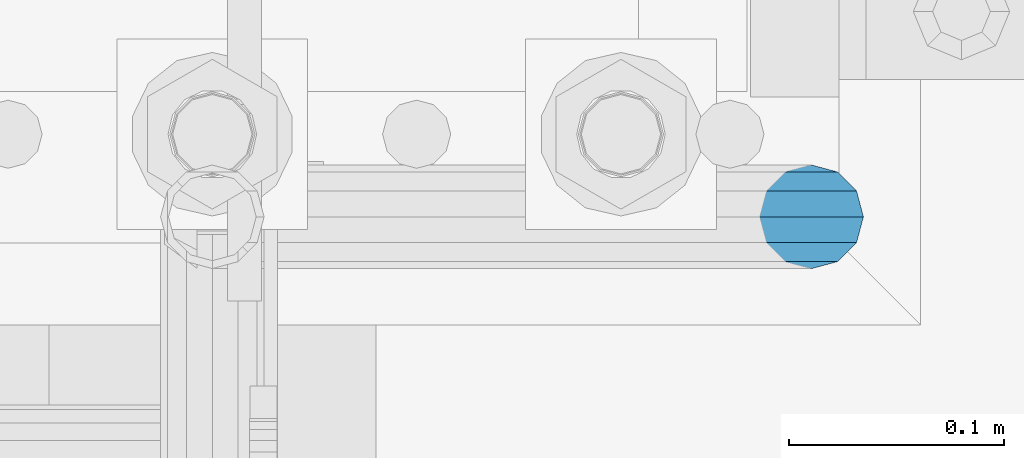
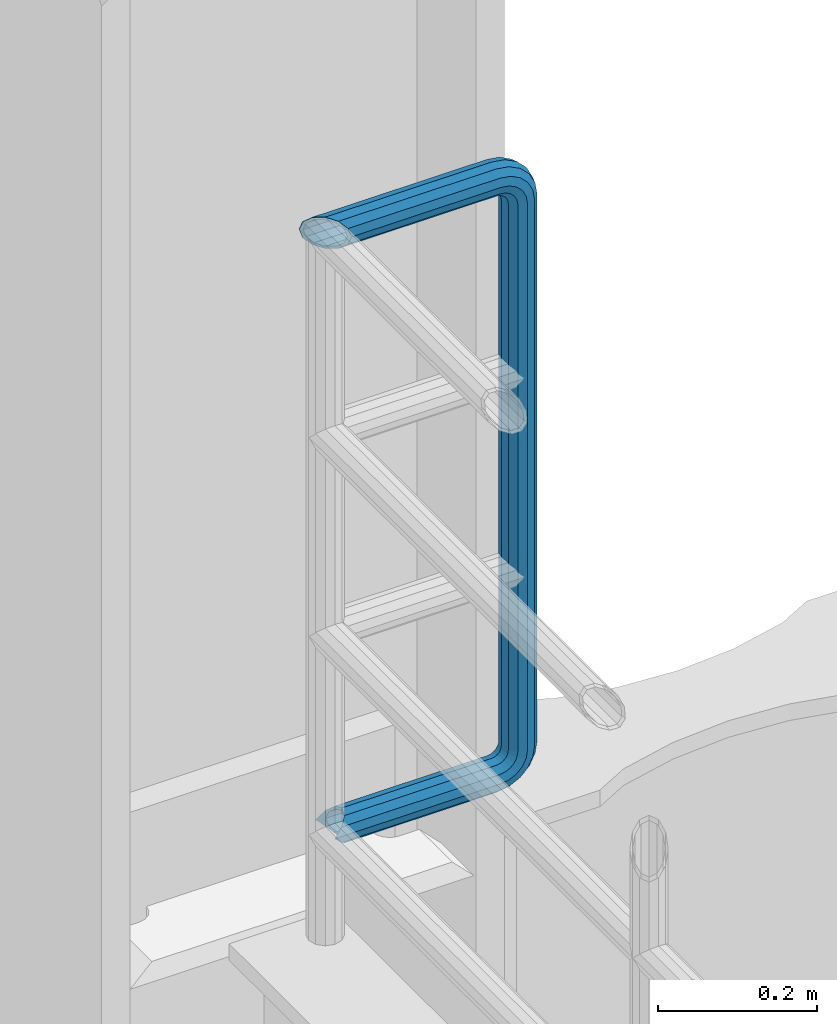
# One storey, part 1054 of 1876: 1 beam, 1 element without a shape of its own.
"""IFC2X3 building model written with IfcOpenShell, lengths in millimetres."""

from ifc_helpers import new_model, si_unit, frame, origin_with_axes, place, context, subcontext, project, spatial, faceted_brep, material, type_object, element, aggregate, save


model = new_model("IFC2X3")

# Units and contexts
model_context = context("Model", 3, precision=1e-05, world=origin_with_axes())
body_context = subcontext(model_context, "Body", "Model", "MODEL_VIEW")
ifc_project = project(units=[si_unit("LENGTHUNIT", "METRE", prefix="MILLI"), si_unit("AREAUNIT", "SQUARE_METRE"), si_unit("VOLUMEUNIT", "CUBIC_METRE"), si_unit("MASSUNIT", "GRAM", prefix="KILO"), si_unit("TIMEUNIT", "SECOND"), si_unit("PLANEANGLEUNIT", "RADIAN"), si_unit("SOLIDANGLEUNIT", "STERADIAN"), si_unit("THERMODYNAMICTEMPERATUREUNIT", "DEGREE_CELSIUS"), si_unit("LUMINOUSINTENSITYUNIT", "LUMEN")], contexts=[model_context])

# Site, building, storey
site_placement = place(None, origin_with_axes())
site = spatial("IfcSite", under=ifc_project, at=site_placement, CompositionType="ELEMENT")
building_placement = place(site_placement, origin_with_axes())
building = spatial("IfcBuilding", under=site, at=building_placement, Name="Undefined", CompositionType="ELEMENT")
storey_placement = place(building_placement, origin_with_axes())
storey = spatial("IfcBuildingStorey", under=building, at=storey_placement, Name="Undefined", CompositionType="ELEMENT", Elevation=0.0)

# Assembly, beam
assembly_placement = place(storey_placement, origin_with_axes())
assembly = element("IfcElementAssembly", 1, at=assembly_placement, inside=storey, Name="RAIL", AssemblyPlace="NOTDEFINED", PredefinedType="RIGID_FRAME")
ifc_material = material()
beam_type = type_object("IfcBeamType", Name="PIPE1-1/2SCH40", PredefinedType="NOTDEFINED")
beam_placement = place(assembly_placement, frame((-3.18323145620525e-12, 13499.7063, 19059.525), z_axis=(0.0, 0.0, 1.0), x_axis=(1.0, 0.0, 0.0)))
beam = element("IfcBeam", 2, at=beam_placement, type_object=beam_type, material=ifc_material, Name="RAIL", ObjectType="PIPE1-1/2SCH40", context=body_context, shape_type="Brep", body=[
    faceted_brep([(1.20714750983051e-12, 24.1299999999974, -914.399963378906), (12.0650000000014, 20.8971929933159, -926.464963378905), (12.0650000000014, 20.8971929933177, -902.334963378908), (12.0650000000014, -20.8971929933195, -902.334963378908), (12.0650000000014, -20.8971929933195, -926.464963378905), (1.52133659548828e-12, -24.130000000001, -914.399963378906), (20.8971929933199, -12.0650000000023, -893.502770385589), (20.8971929933199, -12.0650000000005, -898.533841947723), (15.2545715621378, -17.7076214311819, -904.176463378906), (12.5151929933181, -20.4470000000019, -914.399963378906), (15.2545715621376, -17.7076214311819, -924.623463378906), (20.8971929933199, -12.0650000000005, -930.26608481009), (20.8971929933199, -12.0650000000023, -935.297156372224), (24.1300000000014, -1.81898940354586e-12, -934.846963378906), (24.1300000000014, -1.81898940354586e-12, -938.529963378907), (21.3906214311813, -10.2235000000019, -932.107584810088), (21.3906214311823, 10.2234999999982, -932.107584810088), (20.8971929933199, 12.0650000000005, -930.266084810086), (20.8971929933199, 12.0649999999987, -935.297156372224), (15.2545715621413, 17.7076214311783, -924.623463378906), (12.5151929933216, 20.4469999999983, -914.399963378906), (15.2545715621411, 17.7076214311783, -904.176463378906), (20.8971929933199, 12.0650000000005, -898.533841947727), (20.8971929933199, 12.0649999999987, -893.502770385589), (21.3906214311822, 10.2234999999982, -896.692341947724), (24.1300000000014, 0.0, -893.952963378906), (24.1300000000014, 0.0, -890.269963378905), (21.3906214311814, -10.2235000000019, -896.692341947724), (241.299995422363, -20.8971929933177, 12.0649999999987), (241.299995422363, -24.1299999999992, 0.0), (253.073542436527, -24.1299999999992, -1.86474665447167), (256.801832473661, -20.8971929933177, 9.60975021462946), (241.299995422363, -12.0650000000005, 20.8971929933177), (259.531130206197, -12.0650000000005, 18.0096649141014), (241.299995422363, 0.0, 24.130000000001), (260.530122510796, 0.0, 21.084247083727), (241.299995422363, 12.0650000000005, 20.8971929933177), (259.531130206197, 12.0650000000005, 18.0096649141014), (241.299995422363, 20.8971929933177, 12.0649999999987), (256.801832473661, 20.8971929933177, 9.60975021462946), (241.299995422363, 24.1299999999992, 0.0), (253.073542436527, 24.1299999999992, -1.86474665447167), (241.299995422363, 20.8971929933177, -12.0649999999987), (249.345252399393, 20.8971929933177, -13.3392435235728), (241.299995422363, 12.0650000000005, -20.8971929933177), (246.615954666858, 12.0650000000005, -21.7391582230448), (241.299995422363, 0.0, -24.130000000001), (245.616962362259, 0.0, -24.8137403926739), (241.299995422363, -12.0650000000005, -20.8971929933177), (246.615954666858, -12.0650000000005, -21.7391582230448), (241.299995422363, -20.8971929933177, -12.0649999999987), (249.345252399393, -20.8971929933177, -13.3392435235728), (267.334993896485, 20.8971929933177, -38.0999984741211), (279.399993896485, 24.1299999999992, -38.0999984741211), (279.399993896484, 24.1299999999992, -876.299964904785), (267.334993896484, 20.8971929933177, -876.299964904785), (291.464993896486, 20.8971929933177, -38.0999984741211), (291.464993896484, 20.8971929933177, -876.299964904785), (300.297186889804, 12.0650000000005, -38.0999984741211), (300.297186889803, 12.0650000000005, -876.299964904785), (303.529993896486, 0.0, -38.0999984741211), (303.529993896484, 0.0, -876.299964904785), (300.297186889804, -12.0650000000005, -38.0999984741211), (300.297186889803, -12.0650000000005, -876.299964904785), (291.464993896486, -20.8971929933177, -38.0999984741211), (291.464993896484, -20.8971929933177, -876.299964904785), (279.399993896484, -24.1299999999992, -38.0999984741211), (279.399993896484, -24.1299999999992, -876.299964904785), (267.334993896485, -20.8971929933177, -38.0999984741211), (267.334993896484, -20.8971929933177, -876.299964904785), (258.502800903167, -12.0650000000005, -38.0999984741211), (258.502800903166, -12.0650000000005, -876.299964904785), (255.269993896485, 0.0, -38.0999984741211), (255.269993896484, 0.0, -876.299964904785), (258.502800903167, 12.0650000000005, -38.0999984741211), (258.502800903166, 12.0650000000005, -876.299964904785), (257.660835673438, 12.0650000000005, -881.615924149282), (254.586253503809, 0.0, -880.616931844681), (257.660835673438, -12.0650000000005, -881.615924149282), (266.06075037291, -20.8971929933177, -884.345221881817), (277.535247242011, -24.130000000001, -888.073511918952), (289.009744111112, -20.8971929933195, -891.801801956084), (297.409658810584, -12.0650000000005, -894.531099688622), (300.484240980214, 0.0, -895.53009199322), (297.409658810584, 12.0650000000005, -894.531099688622), (289.009744111112, 20.8971929933177, -891.801801956084), (277.535247242011, 24.1299999999992, -888.073511918952), (266.06075037291, 20.8971929933177, -884.345221881817), (241.299995422364, -1.81898940354586e-12, -938.529963378911), (241.299995422364, -12.0650000000005, -935.297156372228), (241.299995422364, -20.8971929933195, -926.464963378909), (241.299995422363, -24.130000000001, -914.399963378906), (241.299995422363, -20.8971929933195, -902.334963378908), (241.299995422363, -12.0650000000005, -893.502770385589), (241.299995422363, 0.0, -890.269963378909), (241.299995422364, 20.8971929933177, -926.464963378909), (241.299995422364, 12.0649999999987, -935.297156372228), (241.299995422364, 24.1299999999992, -914.39996337891), (241.299995422363, 20.8971929933177, -902.334963378908), (241.299995422363, 12.0649999999987, -893.502770385589), (260.530122510801, 0.0, -935.484210462637), (259.531130206202, 12.0649999999987, -932.409628293008), (259.531130206201, -12.0650000000005, -932.409628293008), (256.801832473666, -20.8971929933195, -924.009713593536), (253.07354243653, -24.130000000001, -912.535216724435), (249.345252399395, -20.8971929933195, -901.060719855333), (246.615954666859, -12.0650000000005, -892.660805155861), (245.61696236226, 0.0, -889.586222986232), (246.615954666859, 12.0649999999987, -892.660805155861), (249.345252399395, 20.8971929933177, -901.060719855333), (253.07354243653, 24.1299999999992, -912.535216724435), (256.801832473666, 20.8971929933177, -924.009713593536), (275.977674493594, 12.0649999999987, -924.029695422345), (270.786241706733, 20.8971929933177, -916.884301193139), (277.877870775644, 0.0, -926.645091230272), (275.977674493608, -12.0650000000005, -924.029695422334), (270.786241706733, -20.8971929933195, -916.884301193139), (263.694612637823, -24.130000000001, -907.123511156005), (256.602983568912, -20.8971929933195, -897.362721118872), (251.411550782037, -12.0650000000005, -890.21732688968), (249.511354500001, 0.0, -887.601931081743), (251.411550782037, 12.0650000000005, -890.21732688968), (256.602983568912, 20.8971929933177, -897.362721118872), (263.694612637823, 24.1299999999992, -907.123511156005), (281.884331710718, 20.8971929933177, -905.786211189152), (272.123541673585, 24.1299999999992, -898.694582120243), (289.029725939912, 12.0650000000005, -910.977643976028), (291.645121747852, 0.0, -912.877840258065), (289.029725939912, -12.0650000000005, -910.977643976028), (281.884331710718, -20.8971929933195, -905.786211189152), (272.123541673585, -24.130000000001, -898.694582120243), (262.362751636451, -20.8971929933195, -891.602953051333), (255.217357407258, -12.0650000000005, -886.411520264461), (252.601961599318, 0.0, -884.511323982424), (255.217357407258, 12.0650000000005, -886.411520264461), (262.362751636451, 20.8971929933177, -891.602953051333), (266.060750372911, 20.8971929933177, -30.0547414970897), (257.660835673439, 12.0650000000005, -32.7840392296275), (277.535247242011, 24.1299999999992, -26.3264514599541), (289.009744111112, 20.8971929933177, -22.5981614228222), (297.409658810584, 12.0650000000005, -19.8688636902843), (300.484240980213, 0.0, -18.8698713856866), (297.409658810584, -12.0650000000005, -19.8688636902843), (289.009744111112, -20.8971929933177, -22.5981614228222), (277.535247242011, -24.1299999999992, -26.3264514599541), (266.060750372911, -20.8971929933177, -30.0547414970897), (257.660835673439, -12.0650000000005, -32.7840392296275), (254.58625350381, 0.0, -33.7830315342253), (255.217357407257, 12.0650000000005, -27.9884431144455), (252.601961599318, 0.0, -29.8886393964822), (262.362751636451, 20.8971929933177, -22.7970103275729), (272.123541673583, 24.1299999999992, -15.7053812586601), (281.884331710716, 20.8971929933177, -8.61375218975081), (289.029725939909, 12.0650000000005, -3.42231940287456), (291.645121747848, 0.0, -1.52212312084157), (289.029725939909, -12.0650000000005, -3.42231940287456), (281.884331710716, -20.8971929933177, -8.61375218975081), (272.123541673583, -24.1299999999992, -15.7053812586601), (262.362751636451, -20.8971929933177, -22.7970103275729), (255.217357407257, -12.0650000000005, -27.9884431144455), (249.511354500002, 0.0, -26.7980322971671), (251.411550782037, -12.0650000000005, -24.1826364892258), (251.411550782037, 12.0650000000005, -24.1826364892258), (256.602983568912, 20.8971929933177, -17.037242260034), (263.694612637822, 24.1299999999992, -7.27645222290084), (270.786241706732, 20.8971929933177, 2.48433781423228), (275.977674493607, 12.0650000000005, 9.62973204342416), (277.877870775642, 0.0, 12.2451278513654), (275.977674493607, -12.0650000000005, 9.62973204342416), (270.786241706732, -20.8971929933177, 2.48433781423228), (263.694612637822, -24.1299999999992, -7.27645222290084), (256.602983568912, -20.8971929933177, -17.037242260034), (24.1299999999854, -24.1299999999992, 0.0), (20.8971929933039, -20.8971929933177, -12.0649999999987), (12.0649999999854, -12.0650000000005, -20.8971929933177), (20.8971929933249, -12.0650000000005, -20.8971929933177), (16.4810997545745, -16.4810997545883, -16.48109323873), (24.1300000000063, 0.0, -24.130000000001), (-1.45519152283669e-11, 0.0, -24.130000000001), (20.8971929933249, 12.0650000000005, -20.8971929933177), (-12.0650000000145, 12.0650000000005, -20.8971929933177), (-20.897192993333, 20.8971929933177, -12.0649999999987), (-12.0649999999986, 20.8971929933177, -12.0649999999987), (12.0650000000064, 20.8971929933177, -12.0649999999987), (-16.481093238746, 16.4810932387318, -16.4810997545865), (0.0, 24.1299999999992, 0.0), (-24.1300000000145, 24.1299999999992, 0.0), (-20.897192993333, 20.8971929933177, 12.0649999999987), (-12.0650000000145, 12.0650000000005, 20.8971929933177), (-1.45519152283669e-11, 0.0, 24.130000000001), (12.0649999999854, -12.0650000000005, 20.8971929933177), (20.8971929933039, -20.8971929933177, 12.0649999999987), (241.299995422363, -17.7076214311801, 10.2235000000001), (241.299995422363, -20.4470000000001, 0.0), (20.4469999999854, -20.4470000000001, 0.0), (17.7076214311658, -17.7076214311801, 10.2235000000001), (241.299995422363, 0.0, 20.4470000000001), (241.299995422363, -10.2235000000001, 17.7076214311819), (10.2234999999854, -10.2235000000001, 17.7076214311819), (-1.45519152283669e-11, 0.0, 20.4470000000001), (241.299995422363, 10.2235000000001, 17.7076214311819), (-10.2235000000145, 10.2235000000001, 17.7076214311819), (241.299995422363, 17.7076214311801, 10.2235000000001), (-17.7076214311949, 17.7076214311801, 10.2235000000001), (241.299995422363, 20.4470000000001, 0.0), (-20.4470000000145, 20.4470000000001, 0.0), (241.299995422363, 17.7076214311801, -10.2235000000001), (-17.7076214311949, 17.7076214311801, -10.2235000000001), (241.299995422363, 10.2235000000001, -17.7076214311819), (-10.2235000000145, 10.2235000000001, -17.7076214311819), (241.299995422363, 0.0, -20.4470000000001), (-1.45519152283669e-11, 0.0, -20.4470000000001), (241.299995422363, -10.2235000000001, -17.7076214311819), (10.2234999999854, -10.2235000000001, -17.7076214311819), (241.299995422363, -17.7076214311801, -10.2235000000001), (17.7076214311658, -17.7076214311801, -10.2235000000001), (258.545498388721, -10.2235000000001, 14.9762020957387), (256.23277767852, -17.7076214311801, 7.85837963987069), (253.073542436527, -20.4470000000001, -1.86474665447167), (249.914307194535, -17.7076214311801, -11.5878729488177), (247.601586484334, -10.2235000000001, -18.7056954046857), (246.755071952542, 0.0, -21.31099924316), (247.601586484334, 10.2235000000001, -18.7056954046857), (249.914307194535, 17.7076214311801, -11.5878729488177), (253.073542436527, 20.4470000000001, -1.86474665447167), (256.23277767852, 17.7076214311801, 7.85837963987069), (258.545498388721, 10.2235000000001, 14.9762020957387), (259.392012920513, 0.0, 17.5815059342131), (275.713057691449, 0.0, 9.26551826108334), (274.10289136825, -10.2235000000001, 7.04931444488102), (274.10289136825, 10.2235000000001, 7.04931444488102), (269.703835164635, 17.7076214311801, 0.994533019089431), (263.694612637822, 20.4470000000001, -7.27645222290084), (257.685390111009, 17.7076214311801, -15.5474374648911), (253.286333907394, 10.2235000000001, -21.6022188906827), (251.676167584195, 0.0, -23.818422706885), (253.286333907394, -10.2235000000001, -21.6022188906827), (257.685390111009, -17.7076214311801, -15.5474374648911), (263.694612637822, -20.4470000000001, -7.27645222290084), (269.703835164635, -17.7076214311801, 0.994533019089431), (286.449308341364, -10.2235000000001, -5.29710252823133), (280.394526915574, -17.7076214311801, -9.69615873184739), (288.665512157566, 0.0, -3.68693620503473), (286.449308341364, 10.2235000000001, -5.29710252823133), (280.394526915574, 17.7076214311801, -9.69615873184739), (272.123541673583, 20.4470000000001, -15.7053812586601), (263.852556431592, 17.7076214311801, -21.7146037854764), (257.797775005802, 10.2235000000001, -26.1136599890888), (255.581571189601, 0.0, -27.723826312289), (257.797775005802, -10.2235000000001, -26.1136599890888), (263.852556431592, -17.7076214311801, -21.7146037854764), (272.123541673583, -20.4470000000001, -15.7053812586601), (287.258373536355, -17.7076214311801, -23.1672162179639), (277.535247242011, -20.4470000000001, -26.3264514599541), (294.376195992223, -10.2235000000001, -20.8544955077632), (296.981499830698, 0.0, -20.00798097597), (294.376195992223, 10.2235000000001, -20.8544955077632), (287.258373536355, 17.7076214311801, -23.1672162179639), (277.535247242011, 20.4470000000001, -26.3264514599541), (267.812120947668, 17.7076214311801, -29.485686701948), (260.6942984918, 10.2235000000001, -31.7984074121487), (258.088994653325, 0.0, -32.6449219439419), (260.6942984918, -10.2235000000001, -31.7984074121487), (267.812120947668, -17.7076214311801, -29.485686701948), (279.399993896484, -20.4470000000001, -38.0999984741211), (269.176493896485, -17.7076214311801, -38.0999984741211), (289.623493896486, -17.7076214311801, -38.0999984741211), (297.107615327666, -10.2235000000001, -38.0999984741211), (299.846993896486, 0.0, -38.0999984741211), (297.107615327666, 10.2235000000001, -38.0999984741211), (289.623493896486, 17.7076214311801, -38.0999984741211), (279.399993896485, 20.4470000000001, -38.0999984741211), (269.176493896485, 17.7076214311801, -38.0999984741211), (261.692372465305, 10.2235000000001, -38.0999984741211), (258.952993896485, 0.0, -38.0999984741211), (261.692372465305, -10.2235000000001, -38.0999984741211), (269.176493896484, -17.7076214311801, -876.299964904785), (261.692372465304, -10.2235000000001, -876.299964904785), (258.952993896484, 0.0, -876.299964904785), (261.692372465304, 10.2235000000001, -876.299964904785), (269.176493896484, 17.7076214311801, -876.299964904785), (279.399993896484, 20.4470000000001, -876.299964904785), (289.623493896484, 17.7076214311801, -876.299964904785), (297.107615327665, 10.2235000000001, -876.299964904785), (299.846993896484, 0.0, -876.299964904785), (297.107615327665, -10.2235000000001, -876.299964904785), (289.623493896484, -17.7076214311801, -876.299964904785), (279.399993896484, -20.4470000000001, -876.299964904785), (277.535247242011, -20.4470000000001, -888.073511918952), (267.812120947667, -17.7076214311801, -884.914276676958), (260.694298491799, -10.2235000000001, -882.601555966758), (258.088994653324, 0.0, -881.755041434964), (260.694298491799, 10.2235000000001, -882.601555966758), (267.812120947668, 17.7076214311801, -884.914276676958), (277.535247242011, 20.4470000000001, -888.073511918952), (287.258373536355, 17.7076214311801, -891.232747160942), (294.376195992223, 10.2235000000001, -893.545467871143), (296.981499830699, 0.0, -894.391982402936), (294.376195992223, -10.2235000000001, -893.545467871143), (287.258373536355, -17.7076214311801, -891.232747160942), (280.394526915577, -17.7076214311801, -904.703804647055), (272.123541673585, -20.4470000000001, -898.694582120243), (286.449308341367, -10.2235000000001, -909.102860850671), (288.665512157569, 0.0, -910.713027173868), (286.449308341367, 10.2235000000001, -909.102860850671), (280.394526915577, 17.7076214311801, -904.703804647055), (272.123541673585, 20.4470000000001, -898.694582120243), (263.852556431593, 17.7076214311801, -892.68535959343), (257.797775005802, 10.2235000000001, -888.286303389817), (255.581571189601, 0.0, -886.676137066617), (257.797775005802, -10.2235000000001, -888.286303389817), (263.852556431593, -17.7076214311801, -892.68535959343), (263.694612637823, -20.4470000000001, -907.123511156005), (257.685390111009, -17.7076214311801, -898.852525914015), (269.703835164636, -17.7076214311801, -915.394496397999), (274.102891368238, -10.2235000000001, -921.449277823798), (275.71305769145, 0.0, -923.66548163999), (274.102891368251, 10.2235000000001, -921.449277823787), (269.703835164636, 17.7076214311801, -915.394496397999), (263.694612637823, 20.4470000000001, -907.123511156005), (257.685390111009, 17.7076214311801, -898.852525914015), (253.286333907394, 10.2235000000001, -892.797744488227), (251.676167584195, 0.0, -890.581540672025), (253.286333907394, -10.2235000000001, -892.797744488227), (249.914307194537, -17.7076214311801, -902.812090430092), (247.601586484335, -10.2235000000001, -895.694267974224), (253.07354243653, -20.4470000000001, -912.535216724435), (256.232777678524, -17.7076214311819, -922.258343018777), (258.545498388725, -10.2235000000001, -929.376165474645), (259.392012920517, 0.0, -931.981469313119), (258.545498388725, 10.2235000000001, -929.376165474645), (256.232777678524, 17.7076214311801, -922.258343018777), (253.07354243653, 20.4470000000001, -912.535216724435), (249.914307194537, 17.7076214311801, -902.812090430092), (247.601586484335, 10.2235000000001, -895.694267974224), (246.755071952543, 0.0, -893.088964135746), (241.299995422363, -10.2235000000001, -896.692341947728), (241.299995422363, 0.0, -893.95296337891), (241.299995422363, -17.7076214311819, -904.17646337891), (241.299995422363, -20.4470000000001, -914.399963378906), (241.299995422364, -17.7076214311819, -924.62346337891), (241.299995422364, -10.2235000000001, -932.107584810088), (241.299995422364, -1.81898940354586e-12, -934.84696337891), (241.299995422364, 10.2234999999982, -932.107584810088), (241.299995422364, 17.7076214311801, -924.62346337891), (241.299995422364, 20.4470000000001, -914.39996337891), (241.299995422363, 17.7076214311801, -904.17646337891), (241.299995422363, 10.2235000000001, -896.692341947728)], [[[0, 1, 2]], [[3, 4, 5]], [[6, 7, 8, 9, 10, 11, 12, 4, 3]], [[13, 14, 12, 11, 15]], [[16, 17, 18, 14, 13]], [[2, 1, 18, 17, 19, 20, 21, 22, 23]], [[23, 22, 24, 25, 26]], [[26, 25, 27, 7, 6]], [[28, 29, 30, 31]], [[32, 28, 31, 33]], [[34, 32, 33, 35]], [[36, 34, 35, 37]], [[38, 36, 37, 39]], [[40, 38, 39, 41]], [[42, 40, 41, 43]], [[44, 42, 43, 45]], [[46, 44, 45, 47]], [[48, 46, 47, 49]], [[50, 48, 49, 51]], [[52, 53, 54, 55]], [[53, 56, 57, 54]], [[56, 58, 59, 57]], [[58, 60, 61, 59]], [[60, 62, 63, 61]], [[62, 64, 65, 63]], [[64, 66, 67, 65]], [[66, 68, 69, 67]], [[68, 70, 71, 69]], [[70, 72, 73, 71]], [[72, 74, 75, 73]], [[73, 75, 76, 77]], [[71, 73, 77, 78]], [[69, 71, 78, 79]], [[67, 69, 79, 80]], [[65, 67, 80, 81]], [[63, 65, 81, 82]], [[61, 63, 82, 83]], [[59, 61, 83, 84]], [[57, 59, 84, 85]], [[54, 57, 85, 86]], [[55, 54, 86, 87]], [[88, 89, 12, 14]], [[89, 90, 4, 12]], [[90, 91, 5, 4]], [[91, 92, 3, 5]], [[92, 93, 6, 3]], [[93, 94, 26, 6]], [[95, 96, 18, 1]], [[97, 95, 1, 0]], [[98, 97, 0, 2]], [[99, 98, 2, 23]], [[94, 99, 23, 26]], [[96, 88, 14, 18]], [[100, 88, 96, 101]], [[102, 89, 88, 100]], [[103, 90, 89, 102]], [[104, 91, 90, 103]], [[105, 92, 91, 104]], [[106, 93, 92, 105]], [[107, 94, 93, 106]], [[108, 99, 94, 107]], [[109, 98, 99, 108]], [[110, 97, 98, 109]], [[111, 95, 97, 110]], [[101, 96, 95, 111]], [[112, 101, 111, 113]], [[114, 100, 101, 112]], [[115, 102, 100, 114]], [[116, 103, 102, 115]], [[117, 104, 103, 116]], [[118, 105, 104, 117]], [[119, 106, 105, 118]], [[120, 107, 106, 119]], [[121, 108, 107, 120]], [[122, 109, 108, 121]], [[123, 110, 109, 122]], [[113, 111, 110, 123]], [[124, 113, 123, 125]], [[126, 112, 113, 124]], [[127, 114, 112, 126]], [[128, 115, 114, 127]], [[129, 116, 115, 128]], [[130, 117, 116, 129]], [[131, 118, 117, 130]], [[132, 119, 118, 131]], [[133, 120, 119, 132]], [[134, 121, 120, 133]], [[135, 122, 121, 134]], [[125, 123, 122, 135]], [[86, 125, 135, 87]], [[85, 124, 125, 86]], [[84, 126, 124, 85]], [[83, 127, 126, 84]], [[82, 128, 127, 83]], [[81, 129, 128, 82]], [[80, 130, 129, 81]], [[79, 131, 130, 80]], [[78, 132, 131, 79]], [[77, 133, 132, 78]], [[76, 134, 133, 77]], [[87, 135, 134, 76]], [[75, 55, 87, 76]], [[74, 52, 55, 75]], [[136, 52, 74, 137]], [[138, 53, 52, 136]], [[139, 56, 53, 138]], [[140, 58, 56, 139]], [[141, 60, 58, 140]], [[142, 62, 60, 141]], [[143, 64, 62, 142]], [[144, 66, 64, 143]], [[145, 68, 66, 144]], [[146, 70, 68, 145]], [[147, 72, 70, 146]], [[137, 74, 72, 147]], [[148, 137, 147, 149]], [[150, 136, 137, 148]], [[151, 138, 136, 150]], [[152, 139, 138, 151]], [[153, 140, 139, 152]], [[154, 141, 140, 153]], [[155, 142, 141, 154]], [[156, 143, 142, 155]], [[157, 144, 143, 156]], [[158, 145, 144, 157]], [[159, 146, 145, 158]], [[149, 147, 146, 159]], [[160, 149, 159, 161]], [[162, 148, 149, 160]], [[163, 150, 148, 162]], [[164, 151, 150, 163]], [[165, 152, 151, 164]], [[166, 153, 152, 165]], [[167, 154, 153, 166]], [[168, 155, 154, 167]], [[169, 156, 155, 168]], [[170, 157, 156, 169]], [[171, 158, 157, 170]], [[161, 159, 158, 171]], [[49, 161, 171, 51]], [[47, 160, 161, 49]], [[45, 162, 160, 47]], [[43, 163, 162, 45]], [[41, 164, 163, 43]], [[39, 165, 164, 41]], [[37, 166, 165, 39]], [[35, 167, 166, 37]], [[33, 168, 167, 35]], [[31, 169, 168, 33]], [[30, 170, 169, 31]], [[51, 171, 170, 30]], [[29, 50, 51, 30]], [[50, 29, 172, 173]], [[174, 175, 48, 50, 173, 176]], [[177, 46, 48, 175, 174, 178]], [[179, 44, 46, 177, 178, 180]], [[181, 182, 183, 42, 44, 179, 180, 184]], [[185, 40, 42, 183, 182, 181, 186]], [[38, 40, 185, 186, 187]], [[36, 38, 187, 188]], [[34, 36, 188, 189]], [[32, 34, 189, 190]], [[28, 32, 190, 191]], [[29, 28, 191, 172]], [[192, 193, 194, 195]], [[196, 197, 198, 199]], [[200, 196, 199, 201]], [[202, 200, 201, 203]], [[204, 202, 203, 205]], [[206, 204, 205, 207]], [[208, 206, 207, 209]], [[210, 208, 209, 211]], [[212, 210, 211, 213]], [[214, 212, 213, 215]], [[193, 214, 215, 194]], [[190, 189, 188, 187, 186, 181, 184, 180, 178, 174, 176, 173, 172, 191], [213, 211, 209, 207, 205, 203, 201, 199, 198, 195, 194, 215]], [[197, 192, 195, 198]], [[192, 197, 216, 217]], [[193, 192, 217, 218]], [[214, 193, 218, 219]], [[212, 214, 219, 220]], [[210, 212, 220, 221]], [[208, 210, 221, 222]], [[206, 208, 222, 223]], [[204, 206, 223, 224]], [[202, 204, 224, 225]], [[200, 202, 225, 226]], [[196, 200, 226, 227]], [[197, 196, 227, 216]], [[227, 228, 229, 216]], [[226, 230, 228, 227]], [[225, 231, 230, 226]], [[224, 232, 231, 225]], [[223, 233, 232, 224]], [[222, 234, 233, 223]], [[221, 235, 234, 222]], [[220, 236, 235, 221]], [[219, 237, 236, 220]], [[218, 238, 237, 219]], [[217, 239, 238, 218]], [[216, 229, 239, 217]], [[229, 240, 241, 239]], [[228, 242, 240, 229]], [[230, 243, 242, 228]], [[231, 244, 243, 230]], [[232, 245, 244, 231]], [[233, 246, 245, 232]], [[234, 247, 246, 233]], [[235, 248, 247, 234]], [[236, 249, 248, 235]], [[237, 250, 249, 236]], [[238, 251, 250, 237]], [[239, 241, 251, 238]], [[241, 252, 253, 251]], [[240, 254, 252, 241]], [[242, 255, 254, 240]], [[243, 256, 255, 242]], [[244, 257, 256, 243]], [[245, 258, 257, 244]], [[246, 259, 258, 245]], [[247, 260, 259, 246]], [[248, 261, 260, 247]], [[249, 262, 261, 248]], [[250, 263, 262, 249]], [[251, 253, 263, 250]], [[253, 264, 265, 263]], [[252, 266, 264, 253]], [[254, 267, 266, 252]], [[255, 268, 267, 254]], [[256, 269, 268, 255]], [[257, 270, 269, 256]], [[258, 271, 270, 257]], [[259, 272, 271, 258]], [[260, 273, 272, 259]], [[261, 274, 273, 260]], [[262, 275, 274, 261]], [[263, 265, 275, 262]], [[275, 265, 276, 277]], [[274, 275, 277, 278]], [[273, 274, 278, 279]], [[272, 273, 279, 280]], [[271, 272, 280, 281]], [[270, 271, 281, 282]], [[269, 270, 282, 283]], [[268, 269, 283, 284]], [[267, 268, 284, 285]], [[266, 267, 285, 286]], [[264, 266, 286, 287]], [[265, 264, 287, 276]], [[276, 287, 288, 289]], [[277, 276, 289, 290]], [[278, 277, 290, 291]], [[279, 278, 291, 292]], [[280, 279, 292, 293]], [[281, 280, 293, 294]], [[282, 281, 294, 295]], [[283, 282, 295, 296]], [[284, 283, 296, 297]], [[285, 284, 297, 298]], [[286, 285, 298, 299]], [[287, 286, 299, 288]], [[299, 300, 301, 288]], [[298, 302, 300, 299]], [[297, 303, 302, 298]], [[296, 304, 303, 297]], [[295, 305, 304, 296]], [[294, 306, 305, 295]], [[293, 307, 306, 294]], [[292, 308, 307, 293]], [[291, 309, 308, 292]], [[290, 310, 309, 291]], [[289, 311, 310, 290]], [[288, 301, 311, 289]], [[301, 312, 313, 311]], [[300, 314, 312, 301]], [[302, 315, 314, 300]], [[303, 316, 315, 302]], [[304, 317, 316, 303]], [[305, 318, 317, 304]], [[306, 319, 318, 305]], [[307, 320, 319, 306]], [[308, 321, 320, 307]], [[309, 322, 321, 308]], [[310, 323, 322, 309]], [[311, 313, 323, 310]], [[313, 324, 325, 323]], [[312, 326, 324, 313]], [[314, 327, 326, 312]], [[315, 328, 327, 314]], [[316, 329, 328, 315]], [[317, 330, 329, 316]], [[318, 331, 330, 317]], [[319, 332, 331, 318]], [[320, 333, 332, 319]], [[321, 334, 333, 320]], [[322, 335, 334, 321]], [[323, 325, 335, 322]], [[325, 336, 337, 335]], [[324, 338, 336, 325]], [[326, 339, 338, 324]], [[327, 340, 339, 326]], [[328, 341, 340, 327]], [[329, 342, 341, 328]], [[330, 343, 342, 329]], [[331, 344, 343, 330]], [[332, 345, 344, 331]], [[333, 346, 345, 332]], [[334, 347, 346, 333]], [[335, 337, 347, 334]], [[347, 337, 25, 24]], [[21, 346, 347, 24, 22]], [[345, 346, 21, 20]], [[344, 345, 20, 19]], [[343, 344, 19, 17, 16]], [[342, 343, 16, 13]], [[341, 342, 13, 15]], [[10, 340, 341, 15, 11]], [[339, 340, 10, 9]], [[338, 339, 9, 8]], [[336, 338, 8, 7, 27]], [[337, 336, 27, 25]]]),
])
aggregate(assembly, [beam])

save(model, "model.ifc")
